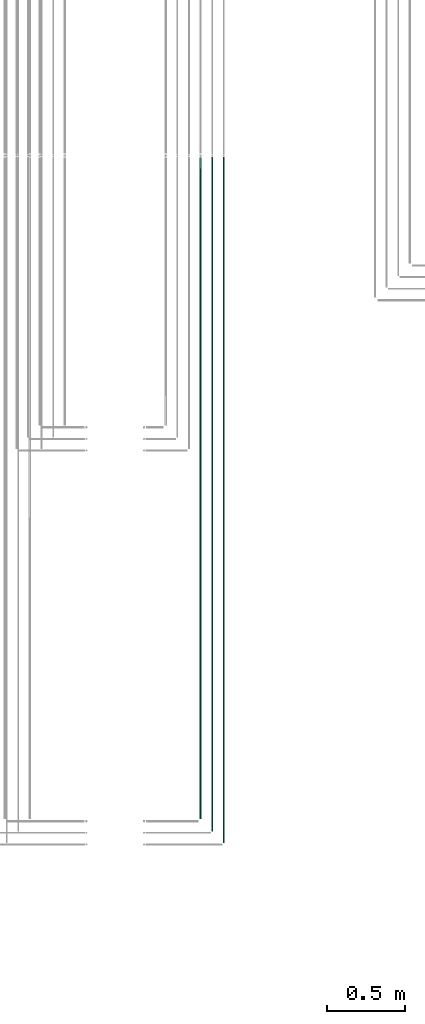
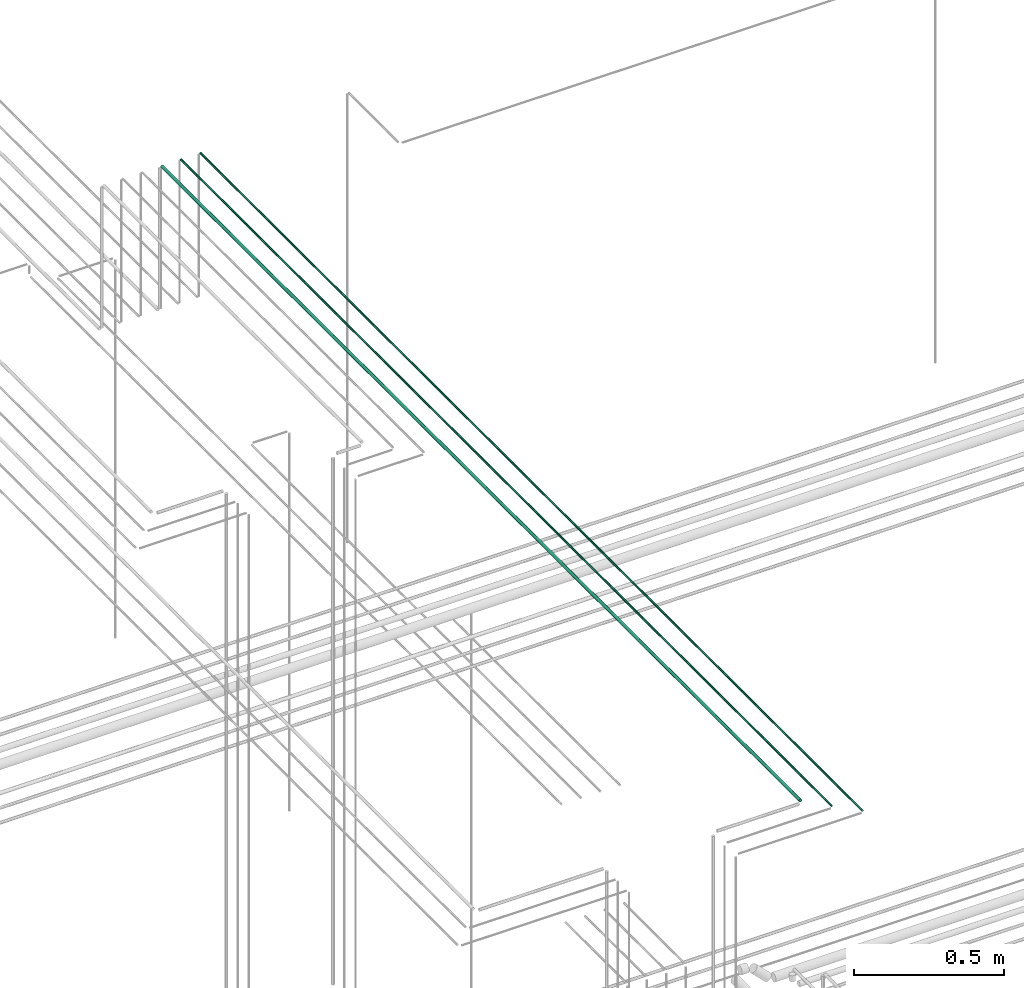
# One storey, part 12 of 331: 3 flow segments.
"""IFC2X3 building model written with IfcOpenShell, lengths in millimetres."""

from ifc_helpers import new_model, entity, si_unit, converted_unit, derived_unit, direction, frame, origin, origin_2d_with_axis, place, context, subcontext, project, spatial, circle, extrude, type_object, element, save


model = new_model("IFC2X3")

# Units and contexts
model_context = context("Model", 3, precision=0.01, world=origin(), true_north=direction((6.12303176911189e-17, 1.0)))
body_context = subcontext(model_context, "Body", "Model", "MODEL_VIEW")
ifc_project = project(units=[si_unit("LENGTHUNIT", "METRE", prefix="MILLI"), si_unit("AREAUNIT", "SQUARE_METRE"), si_unit("VOLUMEUNIT", "CUBIC_METRE"), converted_unit("PLANEANGLEUNIT", "DEGREE", entity("IfcRatioMeasure", 0.0174532925199433), si_unit("PLANEANGLEUNIT", "RADIAN"), dimensions=[0, 0, 0, 0, 0, 0, 0]), si_unit("MASSUNIT", "GRAM", prefix="KILO"), derived_unit("MASSDENSITYUNIT", [(si_unit("MASSUNIT", "GRAM", prefix="KILO"), 1), (si_unit("LENGTHUNIT", "METRE"), -3)]), derived_unit("MOMENTOFINERTIAUNIT", [(si_unit("LENGTHUNIT", "METRE"), 4)]), si_unit("TIMEUNIT", "SECOND"), si_unit("FREQUENCYUNIT", "HERTZ"), si_unit("THERMODYNAMICTEMPERATUREUNIT", "DEGREE_CELSIUS"), derived_unit("THERMALTRANSMITTANCEUNIT", [(si_unit("MASSUNIT", "GRAM", prefix="KILO"), 1), (si_unit("THERMODYNAMICTEMPERATUREUNIT", "KELVIN"), -1), (si_unit("TIMEUNIT", "SECOND"), -3)]), derived_unit("VOLUMETRICFLOWRATEUNIT", [(si_unit("LENGTHUNIT", "METRE"), 3), (si_unit("TIMEUNIT", "SECOND"), -1)]), derived_unit("MASSFLOWRATEUNIT", [(si_unit("MASSUNIT", "GRAM", prefix="KILO"), 1), (si_unit("TIMEUNIT", "SECOND"), -1)]), derived_unit("ROTATIONALFREQUENCYUNIT", [(si_unit("TIMEUNIT", "SECOND"), -1)]), si_unit("ELECTRICCURRENTUNIT", "AMPERE"), si_unit("ELECTRICVOLTAGEUNIT", "VOLT"), si_unit("POWERUNIT", "WATT"), si_unit("FORCEUNIT", "NEWTON", prefix="KILO"), si_unit("ILLUMINANCEUNIT", "LUX"), si_unit("LUMINOUSFLUXUNIT", "LUMEN"), si_unit("LUMINOUSINTENSITYUNIT", "CANDELA"), derived_unit("USERDEFINED", [(si_unit("MASSUNIT", "GRAM", prefix="KILO"), -1), (si_unit("LENGTHUNIT", "METRE"), -2), (si_unit("TIMEUNIT", "SECOND"), 3), (si_unit("LUMINOUSFLUXUNIT", "LUMEN"), 1)]), derived_unit("LINEARVELOCITYUNIT", [(si_unit("LENGTHUNIT", "METRE"), 1), (si_unit("TIMEUNIT", "SECOND"), -1)]), si_unit("PRESSUREUNIT", "PASCAL"), derived_unit("USERDEFINED", [(si_unit("LENGTHUNIT", "METRE"), -2), (si_unit("MASSUNIT", "GRAM", prefix="KILO"), 1), (si_unit("TIMEUNIT", "SECOND"), -2)]), derived_unit("LINEARFORCEUNIT", [(si_unit("MASSUNIT", "GRAM", prefix="KILO"), 1), (si_unit("LENGTHUNIT", "METRE"), 1), (si_unit("TIMEUNIT", "SECOND"), -2), (si_unit("LENGTHUNIT", "METRE"), -1)]), derived_unit("PLANARFORCEUNIT", [(si_unit("MASSUNIT", "GRAM", prefix="KILO"), 1), (si_unit("LENGTHUNIT", "METRE"), 1), (si_unit("TIMEUNIT", "SECOND"), -2), (si_unit("LENGTHUNIT", "METRE"), -2)])], contexts=[model_context])

# Site, building, storey
site_placement = place(None, frame((0.0, -0.00077364408347762, 0.0)))
site = spatial("IfcSite", under=ifc_project, at=site_placement, CompositionType="ELEMENT")
building_placement = place(site_placement, origin())
building = spatial("IfcBuilding", under=site, at=building_placement, CompositionType="ELEMENT")
storey_placement = place(building_placement, origin())
storey = spatial("IfcBuildingStorey", under=building, at=storey_placement, CompositionType="ELEMENT", Elevation=0.0)

# Flow segments
pipe_segment_type = type_object("IfcPipeSegmentType", PredefinedType="NOTDEFINED")
flow_segment_1_placement = place(storey_placement, frame((26313.733655358, 1365.48876707969, 19042.4047277641)))
element("IfcFlowSegment", 1, at=flow_segment_1_placement, inside=storey, type_object=pipe_segment_type, context=body_context, shape_type="SweptSolid", body=[
    extrude(circle(Radius=6.0, at=origin_2d_with_axis()), frame((7.59527223591454, 0.0, 7.5952722359167), z_axis=(0.0, 1.0, 0.0), x_axis=(1.0, 0.0, 0.0)), (0.0, 0.0, 1.0), 4264.13179674766),
])
flow_segment_2_placement = place(storey_placement, frame((26390.733655358, 1286.48876707969, 19044.4047277641)))
element("IfcFlowSegment", 2, at=flow_segment_2_placement, inside=storey, type_object=pipe_segment_type, context=body_context, shape_type="SweptSolid", body=[
    extrude(circle(Radius=4.0, at=origin_2d_with_axis()), frame((5.59527223591499, 0.0, 5.59527223591499), z_axis=(0.0, 1.0, 0.0), x_axis=(1.0, 0.0, 0.0)), (0.0, 0.0, 1.0), 4347.13179674766),
])
flow_segment_3_placement = place(storey_placement, frame((26465.733655358, 1211.48876707969, 19044.4047277641)))
element("IfcFlowSegment", 3, at=flow_segment_3_placement, inside=storey, type_object=pipe_segment_type, context=body_context, shape_type="SweptSolid", body=[
    extrude(circle(Radius=4.0, at=origin_2d_with_axis()), frame((5.59527223591499, 0.0, 5.59527223591499), z_axis=(0.0, 1.0, 0.0), x_axis=(1.0, 0.0, 0.0)), (0.0, 0.0, 1.0), 4422.13179674766),
])

save(model, "model.ifc")
